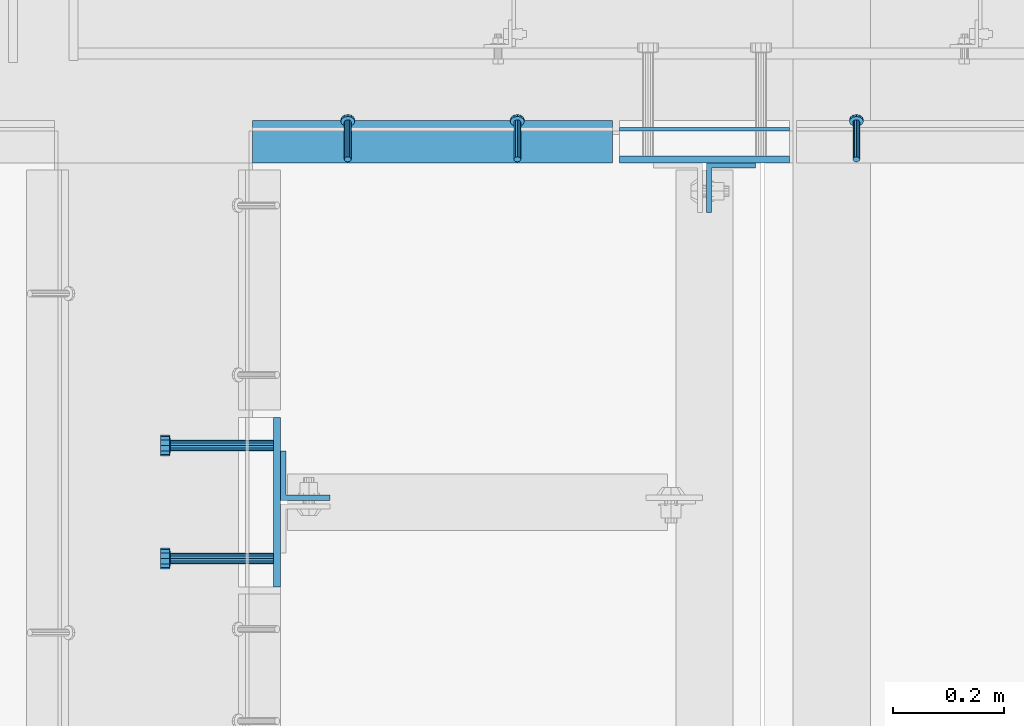
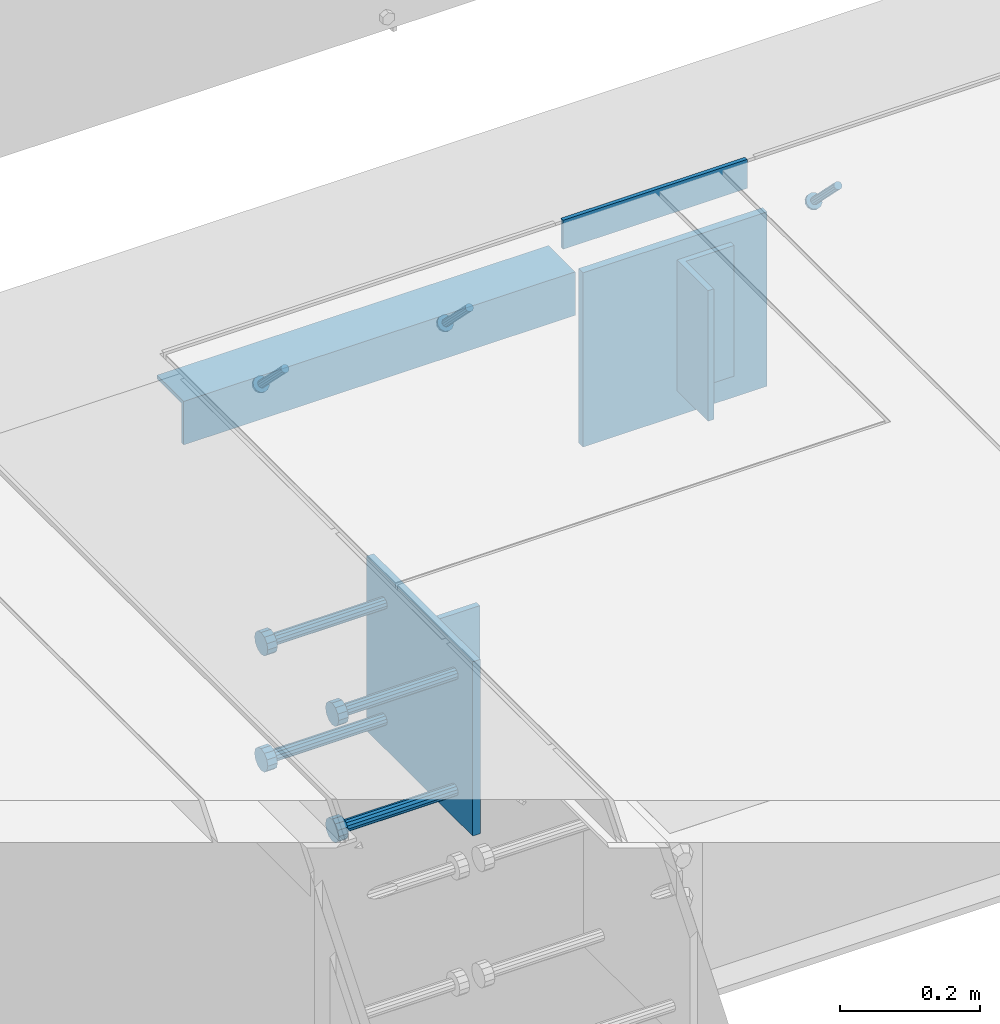
# One storey, part 2084 of 3843: 10 beams, 3 members, 6 elements without a shape of their own.
"""IFC2X3 building model written with IfcOpenShell, lengths in millimetres."""

from ifc_helpers import new_model, si_unit, frame, origin_with_axes, place, context, subcontext, project, spatial, faceted_brep, material, type_object, element, aggregate, save


model = new_model("IFC2X3")

# Units and contexts
model_context = context("Model", 3, precision=1e-05, world=origin_with_axes())
body_context = subcontext(model_context, "Body", "Model", "MODEL_VIEW")
ifc_project = project(units=[si_unit("LENGTHUNIT", "METRE", prefix="MILLI"), si_unit("AREAUNIT", "SQUARE_METRE"), si_unit("VOLUMEUNIT", "CUBIC_METRE"), si_unit("MASSUNIT", "GRAM", prefix="KILO"), si_unit("TIMEUNIT", "SECOND"), si_unit("PLANEANGLEUNIT", "RADIAN"), si_unit("SOLIDANGLEUNIT", "STERADIAN"), si_unit("THERMODYNAMICTEMPERATUREUNIT", "DEGREE_CELSIUS"), si_unit("LUMINOUSINTENSITYUNIT", "LUMEN")], contexts=[model_context])

# Site, building, storey
site_placement = place(None, origin_with_axes())
site = spatial("IfcSite", under=ifc_project, at=site_placement, CompositionType="ELEMENT")
building_placement = place(site_placement, origin_with_axes())
building = spatial("IfcBuilding", under=site, at=building_placement, Name="Undefined", CompositionType="ELEMENT")
storey_placement = place(building_placement, origin_with_axes())
storey = spatial("IfcBuildingStorey", under=building, at=storey_placement, Name="Undefined", CompositionType="ELEMENT", Elevation=0.0)

# Assembly, beam
assembly_1_placement = place(storey_placement, origin_with_axes())
assembly_1 = element("IfcElementAssembly", 1, at=assembly_1_placement, inside=storey, Name="EMBED PLATE", AssemblyPlace="NOTDEFINED", PredefinedType="RIGID_FRAME")
ifc_material_1 = material(Name="STEEL/A36")
beam_type_1 = type_object("IfcBeamType", PredefinedType="NOTDEFINED")
beam_1_placement = place(assembly_1_placement, frame((60020.2, 18751.5499969482, 30454.6), z_axis=(0.0, 0.0, 1.0), x_axis=(1.0, 0.0, 0.0)))
beam_1 = element("IfcBeam", 2, at=beam_1_placement, type_object=beam_type_1, material=ifc_material_1, Name="PLATE", context=body_context, shape_type="Brep", body=[
    faceted_brep([(0.0, 3.17499999999927, -25.4000000000015), (0.0, 3.17499999999927, 25.4000000000015), (304.800000000003, 3.17500000000291, 25.4000000000015), (304.800000000003, 3.17500000000291, -25.4000000000015), (0.0, -3.17499999999927, 25.4000000000015), (304.800000000003, -3.17500000000291, 25.4000000000015), (0.0, -3.17499999999927, -25.4000000000015), (304.800000000003, -3.17500000000291, -25.4000000000015)], [[[0, 1, 2, 3]], [[1, 4, 5, 2]], [[4, 6, 7, 5]], [[6, 0, 3, 7]], [[5, 7, 3, 2]], [[6, 4, 1, 0]]]),
])

# Assembly, member
assembly_2_placement = place(storey_placement, origin_with_axes())
assembly_2 = element("IfcElementAssembly", 3, at=assembly_2_placement, inside=storey, Name="ANGLE", AssemblyPlace="NOTDEFINED", PredefinedType="RIGID_FRAME")
ifc_material_2 = material(Name="STEEL/A108")
member_type = type_object("IfcMemberType", PredefinedType="NOTDEFINED")
member_1_placement = place(assembly_2_placement, frame((60445.6498463031, 18697.5750110749, 30422.8500030518), z_axis=(-1.0, 0.0, 0.0), x_axis=(5.70000238222118e-08, 0.707106781186546, -0.707106781186546)))
member_1 = element("IfcMember", 4, at=member_1_placement, type_object=member_type, material=ifc_material_2, Name="HEADED STUD ANCHOR", context=body_context, shape_type="Brep", body=[
    faceted_brep([(7.27595761418343e-12, -3.18000006675175, 5.5), (0.0, -5.49999999998363, 3.1800000667572), (94.4879985803855, -5.50000000011278, 3.1800000667572), (94.4879985803782, -3.18000006687362, 5.5), (0.0, -6.3499999046162, 0.0), (94.4879985803855, -6.34999990474535, 0.0), (0.0, -5.49999999998363, -3.1800000667572), (94.4879985803855, -5.50000000011278, -3.1800000667572), (7.27595761418343e-12, -3.18000006675175, -5.5), (94.4879985803782, -3.18000006687362, -5.5), (7.27595761418343e-12, -1.81898940354586e-12, -6.34999990463257), (94.4879985803782, -1.20053300634027e-10, -6.34999990463257), (0.0, 3.18000006675175, -5.5), (94.4879985803709, 3.18000006663351, -5.5), (7.27595761418343e-12, 5.49999999998363, -3.1800000667572), (94.4879985803709, 5.49999999987267, -3.1800000667572), (7.27595761418343e-12, 6.3499999046162, 0.0), (94.4879985803673, 6.34999990450706, 0.0), (7.27595761418343e-12, 5.49999999998363, 3.1800000667572), (94.4879985803709, 5.49999999987267, 3.1800000667572), (0.0, 3.18000006675175, 5.5), (94.4879985803709, 3.18000006663351, 5.5), (7.27595761418343e-12, -1.81898940354586e-12, 6.34999990463257), (94.4879985803782, -1.20053300634027e-10, 6.34999990463257), (96.5199985498621, -10.9899997712273, 6.34999990463257), (96.5199985498548, -6.34000015270249, 10.9899997711182), (96.5199985498621, -12.6999998093743, 0.0), (96.5199985498621, -10.9899997712273, -6.34999990463257), (96.5199985498548, -6.34000015270249, -10.9899997711182), (96.5199985498475, -1.21872290037572e-10, -12.6899995803833), (96.5199985498402, 6.34000015245874, -10.9899997711182), (96.519998549833, 10.9899997709817, -6.34999990463257), (96.519998549833, 12.6999998091305, 0.0), (96.519998549833, 10.9899997709817, 6.34999990463257), (96.5199985498402, 6.34000015245874, 10.9899997711182), (96.5199985498475, -1.21872290037572e-10, 12.6899995803833), (101.599998473539, -10.9899997712328, 6.34999990463257), (101.599998473532, -6.34000015270976, 10.9899997711182), (101.599998473539, -12.6999998093797, 0.0), (101.599998473539, -10.9899997712328, -6.34999990463257), (101.599998473532, -6.34000015270976, -10.9899997711182), (101.599998473524, -1.29148247651756e-10, -12.6899995803833), (101.599998473517, 6.34000015245329, -10.9899997711182), (101.59999847351, 10.9899997709763, -6.34999990463257), (101.599998473503, 12.6999998091196, 0.0), (101.59999847351, 10.9899997709763, 6.34999990463257), (101.599998473517, 6.34000015245329, 10.9899997711182), (101.599998473524, -1.29148247651756e-10, 12.6899995803833)], [[[0, 1, 2, 3]], [[1, 4, 5, 2]], [[4, 6, 7, 5]], [[6, 8, 9, 7]], [[8, 10, 11, 9]], [[10, 12, 13, 11]], [[12, 14, 15, 13]], [[14, 16, 17, 15]], [[16, 18, 19, 17]], [[18, 20, 21, 19]], [[20, 22, 23, 21]], [[22, 0, 3, 23]], [[22, 20, 18, 16, 14, 12, 10, 8, 6, 4, 1, 0]], [[3, 2, 24, 25]], [[2, 5, 26, 24]], [[5, 7, 27, 26]], [[7, 9, 28, 27]], [[9, 11, 29, 28]], [[11, 13, 30, 29]], [[13, 15, 31, 30]], [[15, 17, 32, 31]], [[17, 19, 33, 32]], [[19, 21, 34, 33]], [[21, 23, 35, 34]], [[23, 3, 25, 35]], [[25, 24, 36, 37]], [[24, 26, 38, 36]], [[26, 27, 39, 38]], [[27, 28, 40, 39]], [[28, 29, 41, 40]], [[29, 30, 42, 41]], [[30, 31, 43, 42]], [[31, 32, 44, 43]], [[32, 33, 45, 44]], [[33, 34, 46, 45]], [[34, 35, 47, 46]], [[35, 25, 37, 47]], [[38, 39, 40, 41, 42, 43, 44, 45, 46, 47, 37, 36]]]),
])
aggregate(assembly_2, [member_1])

# Assembly, members
assembly_3_placement = place(storey_placement, origin_with_axes())
assembly_3 = element("IfcElementAssembly", 5, at=assembly_3_placement, inside=storey, Name="ANGLE", AssemblyPlace="NOTDEFINED", PredefinedType="RIGID_FRAME")
member_2_placement = place(assembly_3_placement, frame((59836.0499076102, 18697.574989521, 30422.8500030518), z_axis=(-1.0, 0.0, 0.0), x_axis=(5.70000238222118e-08, 0.707106781186546, -0.707106781186546)))
member_2 = element("IfcMember", 6, at=member_2_placement, type_object=member_type, material=ifc_material_2, Name="HEADED STUD ANCHOR", context=body_context, shape_type="Brep", body=[
    faceted_brep([(7.27595761418343e-12, -3.18000006675175, 5.5), (0.0, -5.49999999998363, 3.1800000667572), (94.4879985803855, -5.50000000011278, 3.1800000667572), (94.4879985803782, -3.18000006687362, 5.5), (0.0, -6.3499999046162, 0.0), (94.4879985803855, -6.34999990474535, 0.0), (0.0, -5.49999999998363, -3.1800000667572), (94.4879985803855, -5.50000000011278, -3.1800000667572), (7.27595761418343e-12, -3.18000006675175, -5.5), (94.4879985803782, -3.18000006687362, -5.5), (7.27595761418343e-12, -1.81898940354586e-12, -6.34999990463257), (94.4879985803782, -1.20053300634027e-10, -6.34999990463257), (0.0, 3.18000006675175, -5.5), (94.4879985803709, 3.18000006663351, -5.5), (7.27595761418343e-12, 5.49999999998363, -3.1800000667572), (94.4879985803709, 5.49999999987267, -3.1800000667572), (7.27595761418343e-12, 6.3499999046162, 0.0), (94.4879985803673, 6.34999990450706, 0.0), (7.27595761418343e-12, 5.49999999998363, 3.1800000667572), (94.4879985803709, 5.49999999987267, 3.1800000667572), (0.0, 3.18000006675175, 5.5), (94.4879985803709, 3.18000006663351, 5.5), (7.27595761418343e-12, -1.81898940354586e-12, 6.34999990463257), (94.4879985803782, -1.20053300634027e-10, 6.34999990463257), (96.5199985498621, -10.9899997712273, 6.34999990463257), (96.5199985498548, -6.34000015270249, 10.9899997711182), (96.5199985498621, -12.6999998093743, 0.0), (96.5199985498621, -10.9899997712273, -6.34999990463257), (96.5199985498548, -6.34000015270249, -10.9899997711182), (96.5199985498475, -1.21872290037572e-10, -12.6899995803833), (96.5199985498402, 6.34000015245874, -10.9899997711182), (96.519998549833, 10.9899997709817, -6.34999990463257), (96.519998549833, 12.6999998091305, 0.0), (96.519998549833, 10.9899997709817, 6.34999990463257), (96.5199985498402, 6.34000015245874, 10.9899997711182), (96.5199985498475, -1.21872290037572e-10, 12.6899995803833), (101.599998473539, -10.9899997712328, 6.34999990463257), (101.599998473532, -6.34000015270976, 10.9899997711182), (101.599998473539, -12.6999998093797, 0.0), (101.599998473539, -10.9899997712328, -6.34999990463257), (101.599998473532, -6.34000015270976, -10.9899997711182), (101.599998473524, -1.29148247651756e-10, -12.6899995803833), (101.599998473517, 6.34000015245329, -10.9899997711182), (101.59999847351, 10.9899997709763, -6.34999990463257), (101.599998473503, 12.6999998091196, 0.0), (101.59999847351, 10.9899997709763, 6.34999990463257), (101.599998473517, 6.34000015245329, 10.9899997711182), (101.599998473524, -1.29148247651756e-10, 12.6899995803833)], [[[0, 1, 2, 3]], [[1, 4, 5, 2]], [[4, 6, 7, 5]], [[6, 8, 9, 7]], [[8, 10, 11, 9]], [[10, 12, 13, 11]], [[12, 14, 15, 13]], [[14, 16, 17, 15]], [[16, 18, 19, 17]], [[18, 20, 21, 19]], [[20, 22, 23, 21]], [[22, 0, 3, 23]], [[22, 20, 18, 16, 14, 12, 10, 8, 6, 4, 1, 0]], [[3, 2, 24, 25]], [[2, 5, 26, 24]], [[5, 7, 27, 26]], [[7, 9, 28, 27]], [[9, 11, 29, 28]], [[11, 13, 30, 29]], [[13, 15, 31, 30]], [[15, 17, 32, 31]], [[17, 19, 33, 32]], [[19, 21, 34, 33]], [[21, 23, 35, 34]], [[23, 3, 25, 35]], [[25, 24, 36, 37]], [[24, 26, 38, 36]], [[26, 27, 39, 38]], [[27, 28, 40, 39]], [[28, 29, 41, 40]], [[29, 30, 42, 41]], [[30, 31, 43, 42]], [[31, 32, 44, 43]], [[32, 33, 45, 44]], [[33, 34, 46, 45]], [[34, 35, 47, 46]], [[35, 25, 37, 47]], [[38, 39, 40, 41, 42, 43, 44, 45, 46, 47, 37, 36]]]),
])
member_3_placement = place(assembly_3_placement, frame((59531.2499076102, 18697.574989521, 30422.8500030518), z_axis=(-1.0, 0.0, 0.0), x_axis=(5.70000238222118e-08, 0.707106781186546, -0.707106781186546)))
member_3 = element("IfcMember", 7, at=member_3_placement, type_object=member_type, material=ifc_material_2, Name="HEADED STUD ANCHOR", context=body_context, shape_type="Brep", body=[
    faceted_brep([(7.27595761418343e-12, -3.18000006675175, 5.5), (0.0, -5.49999999998363, 3.1800000667572), (94.4879985803855, -5.50000000011278, 3.1800000667572), (94.4879985803782, -3.18000006687362, 5.5), (0.0, -6.3499999046162, 0.0), (94.4879985803855, -6.34999990474535, 0.0), (0.0, -5.49999999998363, -3.1800000667572), (94.4879985803855, -5.50000000011278, -3.1800000667572), (7.27595761418343e-12, -3.18000006675175, -5.5), (94.4879985803782, -3.18000006687362, -5.5), (7.27595761418343e-12, -1.81898940354586e-12, -6.34999990463257), (94.4879985803782, -1.20053300634027e-10, -6.34999990463257), (0.0, 3.18000006675175, -5.5), (94.4879985803709, 3.18000006663351, -5.5), (7.27595761418343e-12, 5.49999999998363, -3.1800000667572), (94.4879985803709, 5.49999999987267, -3.1800000667572), (7.27595761418343e-12, 6.3499999046162, 0.0), (94.4879985803673, 6.34999990450706, 0.0), (7.27595761418343e-12, 5.49999999998363, 3.1800000667572), (94.4879985803709, 5.49999999987267, 3.1800000667572), (0.0, 3.18000006675175, 5.5), (94.4879985803709, 3.18000006663351, 5.5), (7.27595761418343e-12, -1.81898940354586e-12, 6.34999990463257), (94.4879985803782, -1.20053300634027e-10, 6.34999990463257), (96.5199985498621, -10.9899997712273, 6.34999990463257), (96.5199985498548, -6.34000015270249, 10.9899997711182), (96.5199985498621, -12.6999998093743, 0.0), (96.5199985498621, -10.9899997712273, -6.34999990463257), (96.5199985498548, -6.34000015270249, -10.9899997711182), (96.5199985498475, -1.21872290037572e-10, -12.6899995803833), (96.5199985498402, 6.34000015245874, -10.9899997711182), (96.519998549833, 10.9899997709817, -6.34999990463257), (96.519998549833, 12.6999998091305, 0.0), (96.519998549833, 10.9899997709817, 6.34999990463257), (96.5199985498402, 6.34000015245874, 10.9899997711182), (96.5199985498475, -1.21872290037572e-10, 12.6899995803833), (101.599998473539, -10.9899997712328, 6.34999990463257), (101.599998473532, -6.34000015270976, 10.9899997711182), (101.599998473539, -12.6999998093797, 0.0), (101.599998473539, -10.9899997712328, -6.34999990463257), (101.599998473532, -6.34000015270976, -10.9899997711182), (101.599998473524, -1.29148247651756e-10, -12.6899995803833), (101.599998473517, 6.34000015245329, -10.9899997711182), (101.59999847351, 10.9899997709763, -6.34999990463257), (101.599998473503, 12.6999998091196, 0.0), (101.59999847351, 10.9899997709763, 6.34999990463257), (101.599998473517, 6.34000015245329, 10.9899997711182), (101.599998473524, -1.29148247651756e-10, 12.6899995803833)], [[[0, 1, 2, 3]], [[1, 4, 5, 2]], [[4, 6, 7, 5]], [[6, 8, 9, 7]], [[8, 10, 11, 9]], [[10, 12, 13, 11]], [[12, 14, 15, 13]], [[14, 16, 17, 15]], [[16, 18, 19, 17]], [[18, 20, 21, 19]], [[20, 22, 23, 21]], [[22, 0, 3, 23]], [[22, 20, 18, 16, 14, 12, 10, 8, 6, 4, 1, 0]], [[3, 2, 24, 25]], [[2, 5, 26, 24]], [[5, 7, 27, 26]], [[7, 9, 28, 27]], [[9, 11, 29, 28]], [[11, 13, 30, 29]], [[13, 15, 31, 30]], [[15, 17, 32, 31]], [[17, 19, 33, 32]], [[19, 21, 34, 33]], [[21, 23, 35, 34]], [[23, 3, 25, 35]], [[25, 24, 36, 37]], [[24, 26, 38, 36]], [[26, 27, 39, 38]], [[27, 28, 40, 39]], [[28, 29, 41, 40]], [[29, 30, 42, 41]], [[30, 31, 43, 42]], [[31, 32, 44, 43]], [[32, 33, 45, 44]], [[33, 34, 46, 45]], [[34, 35, 47, 46]], [[35, 25, 37, 47]], [[38, 39, 40, 41, 42, 43, 44, 45, 46, 47, 37, 36]]]),
])

# Assembly, beam
assembly_4_placement = place(storey_placement, origin_with_axes())
assembly_4 = element("IfcElementAssembly", 8, at=assembly_4_placement, inside=storey, Name="EMBED PLATE", AssemblyPlace="NOTDEFINED", PredefinedType="RIGID_FRAME")
beam_type_2 = type_object("IfcBeamType", PredefinedType="NOTDEFINED")
beam_2_placement = place(assembly_4_placement, frame((59404.2500030518, 18081.625, 30422.85), z_axis=(0.0, 1.0, 0.0), x_axis=(0.0, 0.0, -1.0)))
beam_2 = element("IfcBeam", 9, at=beam_2_placement, type_object=beam_type_2, material=ifc_material_1, Name="EMBED PLATE", context=body_context, shape_type="Brep", body=[
    faceted_brep([(-1.0550138540566e-10, 6.34999999999854, -152.400000000664), (1.0550138540566e-10, 6.34999999999854, 152.400000000656), (304.799999999999, 6.34999999999854, 152.400000000001), (304.799999999999, 6.34999999999854, -152.400000000001), (1.0550138540566e-10, -6.34999999999854, 152.400000000656), (304.799999999999, -6.34999999999854, 152.400000000001), (-1.0550138540566e-10, -6.34999999999854, -152.400000000664), (304.799999999999, -6.34999999999854, -152.400000000001)], [[[0, 1, 2, 3]], [[1, 4, 5, 2]], [[4, 6, 7, 5]], [[6, 0, 3, 7]], [[5, 7, 3, 2]], [[6, 4, 1, 0]]]),
])

# Beam
beam_3_placement = place(assembly_1_placement, frame((60172.6, 18697.5749969482, 30422.85), z_axis=(1.0, 0.0, 0.0), x_axis=(0.0, 0.0, -1.0)))
beam_3 = element("IfcBeam", 10, at=beam_3_placement, type_object=beam_type_2, material=ifc_material_1, Name="EMBED PLATE", context=body_context, shape_type="Brep", body=[
    faceted_brep([(-1.0550138540566e-10, 6.34999999999854, -152.400000000664), (1.0550138540566e-10, 6.34999999999854, 152.400000000656), (304.799999999999, 6.34999999999854, 152.400000000001), (304.799999999999, 6.34999999999854, -152.400000000001), (1.0550138540566e-10, -6.34999999999854, 152.400000000656), (304.799999999999, -6.34999999999854, 152.400000000001), (-1.0550138540566e-10, -6.34999999999854, -152.400000000664), (304.799999999999, -6.34999999999854, -152.400000000001)], [[[0, 1, 2, 3]], [[1, 4, 5, 2]], [[4, 6, 7, 5]], [[6, 0, 3, 7]], [[5, 7, 3, 2]], [[6, 4, 1, 0]]]),
])

aggregate(assembly_1, [beam_1, beam_3])

beam_type_3 = type_object("IfcBeamType", Name="L3X3X1/4", PredefinedType="NOTDEFINED")
beam_4_placement = place(assembly_3_placement, frame((59359.7998682441, 18729.324900916, 30391.1000030518), z_axis=(0.0, 0.0, -1.0), x_axis=(1.0, 0.0, 0.0)))
beam_4 = element("IfcBeam", 11, at=beam_4_placement, type_object=beam_type_3, material=ifc_material_1, Name="ANGLE", ObjectType="L3X3X1/4", context=body_context, shape_type="Brep", body=[
    faceted_brep([(0.0, 38.0999999999985, -38.0999999999985), (0.0, 38.0999999999985, 38.0999999999985), (647.700078732363, 38.0999999999985, 38.0999999999985), (647.700078732363, 38.0999999999985, -38.0999999999985), (0.0, 31.75, 38.0999999999985), (647.700078732363, 31.75, 38.0999999999985), (0.0, 31.75, -31.75), (647.700078732363, 31.75, -31.75), (0.0, -38.0999999999985, -31.75), (647.700078732363, -38.0999999999985, -31.75), (0.0, -38.0999999999985, -38.0999999999985), (647.700078732363, -38.0999999999985, -38.0999999999985)], [[[0, 1, 2, 3]], [[1, 4, 5, 2]], [[4, 6, 7, 5]], [[6, 8, 9, 7]], [[8, 10, 11, 9]], [[10, 0, 3, 11]], [[5, 7, 9, 11, 3, 2]], [[10, 8, 6, 4, 1, 0]]]),
])

aggregate(assembly_3, [member_2, member_3, beam_4])

# Assembly, beam
assembly_5_placement = place(storey_placement, origin_with_axes())
assembly_5 = element("IfcElementAssembly", 12, at=assembly_5_placement, inside=storey, Name="BEAM", AssemblyPlace="NOTDEFINED", PredefinedType="RIGID_FRAME")
beam_type_4 = type_object("IfcBeamType", Name="L3-1/2X3-1/2X3/8", PredefinedType="NOTDEFINED")
beam_5_placement = place(assembly_5_placement, frame((59455.0500030518, 18129.25, 30391.1), z_axis=(0.0, 1.0, 0.0), x_axis=(0.0, 0.0, -1.0)))
beam_5 = element("IfcBeam", 13, at=beam_5_placement, type_object=beam_type_4, material=ifc_material_1, Name="ANGLE", ObjectType="L3-1/2X3-1/2X3/8", context=body_context, shape_type="Brep", body=[
    faceted_brep([(-3.63797880709171e-12, 44.4499999999971, -44.4500000000007), (-3.63797880709171e-12, 44.4499999999971, 44.4500000000007), (228.600000000006, 44.4499999999971, 44.4500000000007), (228.600000000006, 44.4499999999971, -44.4500000000007), (0.0, 34.9250000000029, 44.4500000000007), (228.600000000006, 34.9250000000029, 44.4500000000007), (0.0, 34.9250000000029, -34.9250000000029), (228.600000000006, 34.9250000000029, -34.9249999999993), (0.0, -44.4499999999971, -34.9249999999993), (228.600000000006, -44.4499999999971, -34.9249999999993), (3.63797880709171e-12, -44.4499999999971, -44.4500000000007), (228.600000000006, -44.4499999999971, -44.4500000000007)], [[[0, 1, 2, 3]], [[1, 4, 5, 2]], [[4, 6, 7, 5]], [[6, 8, 9, 7]], [[8, 10, 11, 9]], [[10, 0, 3, 11]], [[5, 7, 9, 11, 3, 2]], [[10, 8, 6, 4, 1, 0]]]),
])
aggregate(assembly_5, [beam_5])

assembly_6_placement = place(storey_placement, origin_with_axes())
assembly_6 = element("IfcElementAssembly", 14, at=assembly_6_placement, inside=storey, Name="BEAM", AssemblyPlace="NOTDEFINED", PredefinedType="RIGID_FRAME")
beam_6_placement = place(assembly_6_placement, frame((60220.225, 18646.7749969483, 30391.1), z_axis=(1.0, 0.0, 0.0), x_axis=(0.0, 0.0, -1.0)))
beam_6 = element("IfcBeam", 15, at=beam_6_placement, type_object=beam_type_4, material=ifc_material_1, Name="ANGLE", ObjectType="L3-1/2X3-1/2X3/8", context=body_context, shape_type="Brep", body=[
    faceted_brep([(-3.63797880709171e-12, 44.4499999999971, -44.4500000000007), (-3.63797880709171e-12, 44.4499999999971, 44.4500000000007), (228.600000000006, 44.4499999999971, 44.4500000000007), (228.600000000006, 44.4499999999971, -44.4500000000007), (0.0, 34.9250000000029, 44.4500000000007), (228.600000000006, 34.9250000000029, 44.4500000000007), (0.0, 34.9250000000029, -34.9250000000029), (228.600000000006, 34.9250000000029, -34.9249999999993), (0.0, -44.4499999999971, -34.9249999999993), (228.600000000006, -44.4499999999971, -34.9249999999993), (3.63797880709171e-12, -44.4499999999971, -44.4500000000007), (228.600000000006, -44.4499999999971, -44.4500000000007)], [[[0, 1, 2, 3]], [[1, 4, 5, 2]], [[4, 6, 7, 5]], [[6, 8, 9, 7]], [[8, 10, 11, 9]], [[10, 0, 3, 11]], [[5, 7, 9, 11, 3, 2]], [[10, 8, 6, 4, 1, 0]]]),
])
aggregate(assembly_6, [beam_6])

# Beam
beam_type_5 = type_object("IfcBeamType", PredefinedType="NOTDEFINED")
beam_7_placement = place(assembly_4_placement, frame((59397.9000030518, 17980.025, 30372.05), z_axis=(0.0, -1.0, 0.0), x_axis=(-1.0, 0.0, 0.0)))
beam_7 = element("IfcBeam", 16, at=beam_7_placement, type_object=beam_type_5, material=ifc_material_2, Name="HEADED STUD ANCHOR", context=body_context, shape_type="Brep", body=[
    faceted_brep([(0.0, -9.52000045776367, 0.0), (0.0, -8.25, -4.76000022888184), (184.912000000004, -8.25, -4.76000022888184), (184.912000000004, -9.52000045776367, 0.0), (0.0, -4.76000022888184, -8.25), (184.912000000004, -4.76000022888184, -8.25), (0.0, 0.0, -9.52000045776367), (184.912000000004, 0.0, -9.52000045776367), (0.0, 4.76000022888184, -8.25), (184.912000000004, 4.76000022888184, -8.25), (0.0, 8.25, -4.76000022888184), (184.912000000004, 8.25, -4.76000022888184), (0.0, 9.52000045776367, 0.0), (184.912000000004, 9.52000045776367, 0.0), (0.0, 8.25, 4.76000022888184), (184.912000000004, 8.25, 4.76000022888184), (0.0, 4.76000022888184, 8.25), (184.912000000004, 4.76000022888184, 8.25), (0.0, 0.0, 9.52000045776367), (184.912000000004, 0.0, 9.52000045776367), (0.0, -4.76000022888184, 8.25), (184.912000000004, -4.76000022888184, 8.25), (0.0, -8.25, 4.76000022888184), (184.912000000004, -8.25, 4.76000022888184), (186.944000000003, -16.5, -9.52000045776367), (186.944000000003, -19.0499992370605, 0.0), (186.944000000003, -9.52000045776367, -16.5), (186.944000000003, 0.0, -19.0499992370605), (186.944000000003, 9.52000045776367, -16.5), (186.944000000003, 16.5, -9.52000045776367), (186.944000000003, 19.0499992370605, 0.0), (186.944000000003, 16.5, 9.52000045776367), (186.944000000003, 9.52000045776367, 16.5), (186.944000000003, 0.0, 19.0499992370605), (186.944000000003, -9.52000045776367, 16.5), (186.944000000003, -16.5, 9.52000045776367), (203.199999999997, -16.5, -9.52000045776367), (203.199999999997, -19.0499992370605, 0.0), (203.199999999997, -9.52000045776367, -16.5), (203.199999999997, 0.0, -19.0499992370605), (203.199999999997, 9.52000045776367, -16.5), (203.199999999997, 16.5, -9.52000045776367), (203.199999999997, 19.0499992370605, 0.0), (203.199999999997, 16.5, 9.52000045776367), (203.199999999997, 9.52000045776367, 16.5), (203.199999999997, 0.0, 19.0499992370605), (203.199999999997, -9.52000045776367, 16.5), (203.199999999997, -16.5, 9.52000045776367)], [[[0, 1, 2, 3]], [[1, 4, 5, 2]], [[4, 6, 7, 5]], [[6, 8, 9, 7]], [[8, 10, 11, 9]], [[10, 12, 13, 11]], [[12, 14, 15, 13]], [[14, 16, 17, 15]], [[16, 18, 19, 17]], [[18, 20, 21, 19]], [[20, 22, 23, 21]], [[22, 0, 3, 23]], [[22, 20, 18, 16, 14, 12, 10, 8, 6, 4, 1, 0]], [[3, 2, 24, 25]], [[2, 5, 26, 24]], [[5, 7, 27, 26]], [[7, 9, 28, 27]], [[9, 11, 29, 28]], [[11, 13, 30, 29]], [[13, 15, 31, 30]], [[15, 17, 32, 31]], [[17, 19, 33, 32]], [[19, 21, 34, 33]], [[21, 23, 35, 34]], [[23, 3, 25, 35]], [[25, 24, 36, 37]], [[24, 26, 38, 36]], [[26, 27, 39, 38]], [[27, 28, 40, 39]], [[28, 29, 41, 40]], [[29, 30, 42, 41]], [[30, 31, 43, 42]], [[31, 32, 44, 43]], [[32, 33, 45, 44]], [[33, 34, 46, 45]], [[34, 35, 47, 46]], [[35, 25, 37, 47]], [[38, 39, 40, 41, 42, 43, 44, 45, 46, 47, 37, 36]]]),
])

beam_8_placement = place(assembly_4_placement, frame((59397.9000030518, 17980.025, 30168.85), z_axis=(0.0, -1.0, 0.0), x_axis=(-1.0, 0.0, 0.0)))
beam_8 = element("IfcBeam", 17, at=beam_8_placement, type_object=beam_type_5, material=ifc_material_2, Name="HEADED STUD ANCHOR", context=body_context, shape_type="Brep", body=[
    faceted_brep([(0.0, -9.52000045776367, 0.0), (0.0, -8.25, -4.76000022888184), (184.912000000004, -8.25, -4.76000022888184), (184.912000000004, -9.52000045776367, 0.0), (0.0, -4.76000022888184, -8.25), (184.912000000004, -4.76000022888184, -8.25), (0.0, 0.0, -9.52000045776367), (184.912000000004, 0.0, -9.52000045776367), (0.0, 4.76000022888184, -8.25), (184.912000000004, 4.76000022888184, -8.25), (0.0, 8.25, -4.76000022888184), (184.912000000004, 8.25, -4.76000022888184), (0.0, 9.52000045776367, 0.0), (184.912000000004, 9.52000045776367, 0.0), (0.0, 8.25, 4.76000022888184), (184.912000000004, 8.25, 4.76000022888184), (0.0, 4.76000022888184, 8.25), (184.912000000004, 4.76000022888184, 8.25), (0.0, 0.0, 9.52000045776367), (184.912000000004, 0.0, 9.52000045776367), (0.0, -4.76000022888184, 8.25), (184.912000000004, -4.76000022888184, 8.25), (0.0, -8.25, 4.76000022888184), (184.912000000004, -8.25, 4.76000022888184), (186.944000000003, -16.5, -9.52000045776367), (186.944000000003, -19.0499992370605, 0.0), (186.944000000003, -9.52000045776367, -16.5), (186.944000000003, 0.0, -19.0499992370605), (186.944000000003, 9.52000045776367, -16.5), (186.944000000003, 16.5, -9.52000045776367), (186.944000000003, 19.0499992370605, 0.0), (186.944000000003, 16.5, 9.52000045776367), (186.944000000003, 9.52000045776367, 16.5), (186.944000000003, 0.0, 19.0499992370605), (186.944000000003, -9.52000045776367, 16.5), (186.944000000003, -16.5, 9.52000045776367), (203.199999999997, -16.5, -9.52000045776367), (203.199999999997, -19.0499992370605, 0.0), (203.199999999997, -9.52000045776367, -16.5), (203.199999999997, 0.0, -19.0499992370605), (203.199999999997, 9.52000045776367, -16.5), (203.199999999997, 16.5, -9.52000045776367), (203.199999999997, 19.0499992370605, 0.0), (203.199999999997, 16.5, 9.52000045776367), (203.199999999997, 9.52000045776367, 16.5), (203.199999999997, 0.0, 19.0499992370605), (203.199999999997, -9.52000045776367, 16.5), (203.199999999997, -16.5, 9.52000045776367)], [[[0, 1, 2, 3]], [[1, 4, 5, 2]], [[4, 6, 7, 5]], [[6, 8, 9, 7]], [[8, 10, 11, 9]], [[10, 12, 13, 11]], [[12, 14, 15, 13]], [[14, 16, 17, 15]], [[16, 18, 19, 17]], [[18, 20, 21, 19]], [[20, 22, 23, 21]], [[22, 0, 3, 23]], [[22, 20, 18, 16, 14, 12, 10, 8, 6, 4, 1, 0]], [[3, 2, 24, 25]], [[2, 5, 26, 24]], [[5, 7, 27, 26]], [[7, 9, 28, 27]], [[9, 11, 29, 28]], [[11, 13, 30, 29]], [[13, 15, 31, 30]], [[15, 17, 32, 31]], [[17, 19, 33, 32]], [[19, 21, 34, 33]], [[21, 23, 35, 34]], [[23, 3, 25, 35]], [[25, 24, 36, 37]], [[24, 26, 38, 36]], [[26, 27, 39, 38]], [[27, 28, 40, 39]], [[28, 29, 41, 40]], [[29, 30, 42, 41]], [[30, 31, 43, 42]], [[31, 32, 44, 43]], [[32, 33, 45, 44]], [[33, 34, 46, 45]], [[34, 35, 47, 46]], [[35, 25, 37, 47]], [[38, 39, 40, 41, 42, 43, 44, 45, 46, 47, 37, 36]]]),
])

beam_9_placement = place(assembly_4_placement, frame((59397.9000030518, 18183.225, 30372.05), z_axis=(0.0, -1.0, 0.0), x_axis=(-1.0, 0.0, 0.0)))
beam_9 = element("IfcBeam", 18, at=beam_9_placement, type_object=beam_type_5, material=ifc_material_1, Name="PLATE", context=body_context, shape_type="Brep", body=[
    faceted_brep([(0.0, -9.52000045776367, 0.0), (0.0, -8.25, -4.76000022888184), (184.912000000004, -8.25, -4.76000022888184), (184.912000000004, -9.52000045776367, 0.0), (0.0, -4.76000022888184, -8.25), (184.912000000004, -4.76000022888184, -8.25), (0.0, 0.0, -9.52000045776367), (184.912000000004, 0.0, -9.52000045776367), (0.0, 4.76000022888184, -8.25), (184.912000000004, 4.76000022888184, -8.25), (0.0, 8.25, -4.76000022888184), (184.912000000004, 8.25, -4.76000022888184), (0.0, 9.52000045776367, 0.0), (184.912000000004, 9.52000045776367, 0.0), (0.0, 8.25, 4.76000022888184), (184.912000000004, 8.25, 4.76000022888184), (0.0, 4.76000022888184, 8.25), (184.912000000004, 4.76000022888184, 8.25), (0.0, 0.0, 9.52000045776367), (184.912000000004, 0.0, 9.52000045776367), (0.0, -4.76000022888184, 8.25), (184.912000000004, -4.76000022888184, 8.25), (0.0, -8.25, 4.76000022888184), (184.912000000004, -8.25, 4.76000022888184), (186.944000000003, -16.5, -9.52000045776367), (186.944000000003, -19.0499992370605, 0.0), (186.944000000003, -9.52000045776367, -16.5), (186.944000000003, 0.0, -19.0499992370605), (186.944000000003, 9.52000045776367, -16.5), (186.944000000003, 16.5, -9.52000045776367), (186.944000000003, 19.0499992370605, 0.0), (186.944000000003, 16.5, 9.52000045776367), (186.944000000003, 9.52000045776367, 16.5), (186.944000000003, 0.0, 19.0499992370605), (186.944000000003, -9.52000045776367, 16.5), (186.944000000003, -16.5, 9.52000045776367), (203.199999999997, -16.5, -9.52000045776367), (203.199999999997, -19.0499992370605, 0.0), (203.199999999997, -9.52000045776367, -16.5), (203.199999999997, 0.0, -19.0499992370605), (203.199999999997, 9.52000045776367, -16.5), (203.199999999997, 16.5, -9.52000045776367), (203.199999999997, 19.0499992370605, 0.0), (203.199999999997, 16.5, 9.52000045776367), (203.199999999997, 9.52000045776367, 16.5), (203.199999999997, 0.0, 19.0499992370605), (203.199999999997, -9.52000045776367, 16.5), (203.199999999997, -16.5, 9.52000045776367)], [[[0, 1, 2, 3]], [[1, 4, 5, 2]], [[4, 6, 7, 5]], [[6, 8, 9, 7]], [[8, 10, 11, 9]], [[10, 12, 13, 11]], [[12, 14, 15, 13]], [[14, 16, 17, 15]], [[16, 18, 19, 17]], [[18, 20, 21, 19]], [[20, 22, 23, 21]], [[22, 0, 3, 23]], [[22, 20, 18, 16, 14, 12, 10, 8, 6, 4, 1, 0]], [[3, 2, 24, 25]], [[2, 5, 26, 24]], [[5, 7, 27, 26]], [[7, 9, 28, 27]], [[9, 11, 29, 28]], [[11, 13, 30, 29]], [[13, 15, 31, 30]], [[15, 17, 32, 31]], [[17, 19, 33, 32]], [[19, 21, 34, 33]], [[21, 23, 35, 34]], [[23, 3, 25, 35]], [[25, 24, 36, 37]], [[24, 26, 38, 36]], [[26, 27, 39, 38]], [[27, 28, 40, 39]], [[28, 29, 41, 40]], [[29, 30, 42, 41]], [[30, 31, 43, 42]], [[31, 32, 44, 43]], [[32, 33, 45, 44]], [[33, 34, 46, 45]], [[34, 35, 47, 46]], [[35, 25, 37, 47]], [[38, 39, 40, 41, 42, 43, 44, 45, 46, 47, 37, 36]]]),
])

beam_10_placement = place(assembly_4_placement, frame((59397.9000030518, 18183.225, 30168.85), z_axis=(0.0, -1.0, 0.0), x_axis=(-1.0, 0.0, 0.0)))
beam_10 = element("IfcBeam", 19, at=beam_10_placement, type_object=beam_type_5, material=ifc_material_2, Name="HEADED STUD ANCHOR", context=body_context, shape_type="Brep", body=[
    faceted_brep([(0.0, -9.52000045776367, 0.0), (0.0, -8.25, -4.76000022888184), (184.912000000004, -8.25, -4.76000022888184), (184.912000000004, -9.52000045776367, 0.0), (0.0, -4.76000022888184, -8.25), (184.912000000004, -4.76000022888184, -8.25), (0.0, 0.0, -9.52000045776367), (184.912000000004, 0.0, -9.52000045776367), (0.0, 4.76000022888184, -8.25), (184.912000000004, 4.76000022888184, -8.25), (0.0, 8.25, -4.76000022888184), (184.912000000004, 8.25, -4.76000022888184), (0.0, 9.52000045776367, 0.0), (184.912000000004, 9.52000045776367, 0.0), (0.0, 8.25, 4.76000022888184), (184.912000000004, 8.25, 4.76000022888184), (0.0, 4.76000022888184, 8.25), (184.912000000004, 4.76000022888184, 8.25), (0.0, 0.0, 9.52000045776367), (184.912000000004, 0.0, 9.52000045776367), (0.0, -4.76000022888184, 8.25), (184.912000000004, -4.76000022888184, 8.25), (0.0, -8.25, 4.76000022888184), (184.912000000004, -8.25, 4.76000022888184), (186.944000000003, -16.5, -9.52000045776367), (186.944000000003, -19.0499992370605, 0.0), (186.944000000003, -9.52000045776367, -16.5), (186.944000000003, 0.0, -19.0499992370605), (186.944000000003, 9.52000045776367, -16.5), (186.944000000003, 16.5, -9.52000045776367), (186.944000000003, 19.0499992370605, 0.0), (186.944000000003, 16.5, 9.52000045776367), (186.944000000003, 9.52000045776367, 16.5), (186.944000000003, 0.0, 19.0499992370605), (186.944000000003, -9.52000045776367, 16.5), (186.944000000003, -16.5, 9.52000045776367), (203.199999999997, -16.5, -9.52000045776367), (203.199999999997, -19.0499992370605, 0.0), (203.199999999997, -9.52000045776367, -16.5), (203.199999999997, 0.0, -19.0499992370605), (203.199999999997, 9.52000045776367, -16.5), (203.199999999997, 16.5, -9.52000045776367), (203.199999999997, 19.0499992370605, 0.0), (203.199999999997, 16.5, 9.52000045776367), (203.199999999997, 9.52000045776367, 16.5), (203.199999999997, 0.0, 19.0499992370605), (203.199999999997, -9.52000045776367, 16.5), (203.199999999997, -16.5, 9.52000045776367)], [[[0, 1, 2, 3]], [[1, 4, 5, 2]], [[4, 6, 7, 5]], [[6, 8, 9, 7]], [[8, 10, 11, 9]], [[10, 12, 13, 11]], [[12, 14, 15, 13]], [[14, 16, 17, 15]], [[16, 18, 19, 17]], [[18, 20, 21, 19]], [[20, 22, 23, 21]], [[22, 0, 3, 23]], [[22, 20, 18, 16, 14, 12, 10, 8, 6, 4, 1, 0]], [[3, 2, 24, 25]], [[2, 5, 26, 24]], [[5, 7, 27, 26]], [[7, 9, 28, 27]], [[9, 11, 29, 28]], [[11, 13, 30, 29]], [[13, 15, 31, 30]], [[15, 17, 32, 31]], [[17, 19, 33, 32]], [[19, 21, 34, 33]], [[21, 23, 35, 34]], [[23, 3, 25, 35]], [[25, 24, 36, 37]], [[24, 26, 38, 36]], [[26, 27, 39, 38]], [[27, 28, 40, 39]], [[28, 29, 41, 40]], [[29, 30, 42, 41]], [[30, 31, 43, 42]], [[31, 32, 44, 43]], [[32, 33, 45, 44]], [[33, 34, 46, 45]], [[34, 35, 47, 46]], [[35, 25, 37, 47]], [[38, 39, 40, 41, 42, 43, 44, 45, 46, 47, 37, 36]]]),
])

aggregate(assembly_4, [beam_7, beam_8, beam_9, beam_10, beam_2])

save(model, "model.ifc")
